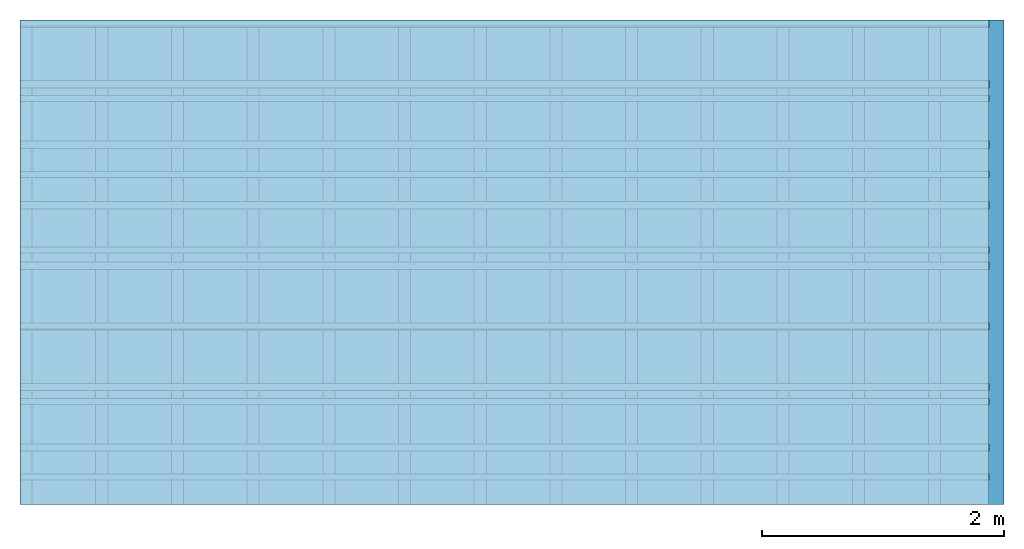
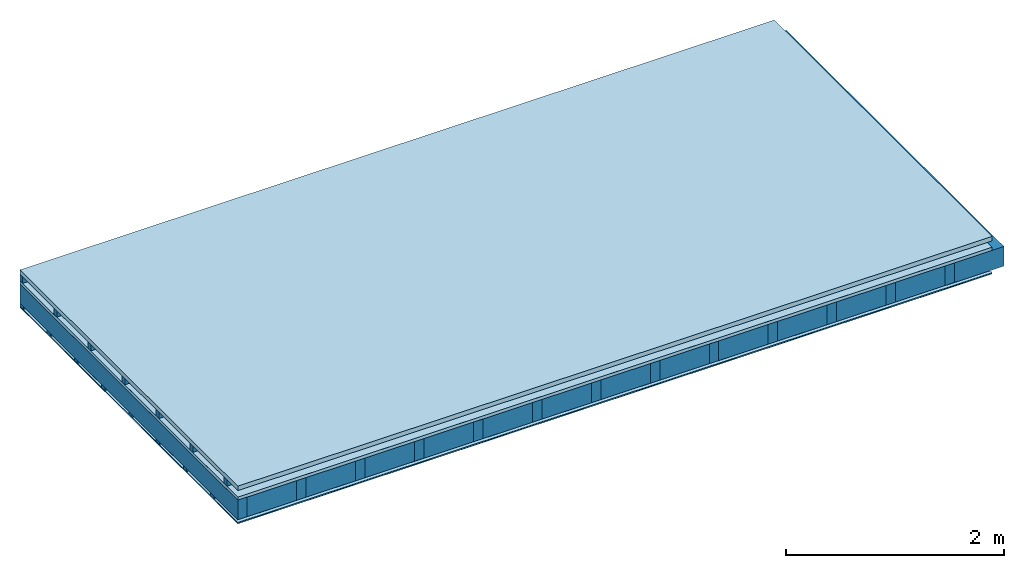
# One storey: 6 plates, 4 members, 1 element without a shape of its own.
"""IFC4 building model written with IfcOpenShell, lengths in metres."""

from ifc_helpers import new_model, si_unit, derived_unit, direction, frame, frame_2d, origin, origin_with_axes, place, context, project, spatial, rectangle, extrude, material, layer, layer_set, type_object, element, aggregate, save


model = new_model("IFC4")

# Units and contexts
plan_context = context("Plan", 3, precision=1e-05, world=origin(), true_north=direction((0.0, 1.0)))
model_context = context("Model", 3, precision=1e-05, world=origin(), true_north=direction((0.0, 1.0)))
ifc_project = project(units=[si_unit("LENGTHUNIT", "METRE"), derived_unit("SOUNDPRESSUREUNIT", [(si_unit("PRESSUREUNIT", "PASCAL", prefix="MICRO"), 0)]), si_unit("ENERGYUNIT", "JOULE", prefix="MEGA"), si_unit("MASSUNIT", "GRAM", prefix="KILO"), derived_unit("THERMALTRANSMITTANCEUNIT", [(si_unit("POWERUNIT", "WATT"), 1), (si_unit("AREAUNIT", "SQUARE_METRE"), -1), (si_unit("THERMODYNAMICTEMPERATUREUNIT", "KELVIN"), -1)]), derived_unit("AREADENSITYUNIT", [(si_unit("MASSUNIT", "GRAM", prefix="KILO"), 1), (si_unit("AREAUNIT", "SQUARE_METRE"), -1)]), derived_unit("USERDEFINED", [(si_unit("ENERGYUNIT", "JOULE", prefix="MEGA"), 1), (si_unit("AREAUNIT", "SQUARE_METRE"), -1)])], contexts=[plan_context, model_context])

# Site, building, storey
site = spatial("IfcSite", under=ifc_project)
building_placement = place(None, origin())
building = spatial("IfcBuilding", under=site, at=building_placement)
storey_placement = place(building_placement, origin())
storey = spatial("IfcBuildingStorey", under=building, at=storey_placement)

# Slab, members, plates
ifc_material_1 = material(Name="Roof tiles", Category="03.015")
ifc_layer_1 = layer(ifc_material_1, 0.05, Name="Roofing")
ifc_layer_2 = layer(None, 0.072, Name="Battens / profiles")
ifc_material_2 = material(Name="Roofing underlay", Category="09.008")
ifc_layer_3 = layer(ifc_material_2, 0.00018, Name="Under the roof")
ifc_material_3 = material(Category="10.009")
ifc_layer_4 = layer(ifc_material_3, 0.035, Name="Sub-floor")
ifc_material_4 = material(Name="of the art")
ifc_layer_5 = layer(ifc_material_4, 0.0, Name="Bond")
ifc_layer_6 = layer(None, 0.22, Name="Supporting structure")
ifc_material_5 = material(Name="Vapor barrier polyethylene (PE)", Category="09.002")
ifc_layer_7 = layer(ifc_material_5, 0.00025, Name="Vapor barrier")
ifc_layer_8 = layer(None, 0.03, Name="Battens / profiles")
ifc_material_6 = material(Name="Plasterboard type A", Category="03.008")
ifc_layer_9 = layer(ifc_material_6, 0.0125, Name="Covering below 1st layer")
ifc_material_7 = material(Category="04.001")
ifc_layer_10 = layer(ifc_material_7, 0.003, Name="Surface below")
ifc_layer_set = layer_set([ifc_layer_1, ifc_layer_2, ifc_layer_3, ifc_layer_4, ifc_layer_5, ifc_layer_6, ifc_layer_7, ifc_layer_8, ifc_layer_9, ifc_layer_10])
slab_type = type_object("IfcSlabType", Name="E0188", PredefinedType="NOTDEFINED", material=ifc_layer_set)
slab_placement = place(None, frame((0.0, 0.0, 0.0), z_axis=(0.0, 0.0, -1.0), x_axis=(1.0, 0.0, 0.0)))
slab = element("IfcSlab", 1, at=slab_placement, inside=storey, type_object=slab_type, material=ifc_layer_set, Name="Slab #1")
ifc_material_8 = material()
member_1_placement = place(slab_placement, origin())
member_1 = element("IfcMember", 2, at=member_1_placement, material=ifc_material_8, Name="Battens / profiles", context=plan_context, shape_type="SweptSolid", body=[
    extrude(rectangle(XDim=0.05, YDim=0.072, at=frame_2d((0.025, 0.036), x_axis=(1.0, 0.0))), frame((0.0, 0.0, 0.05), z_axis=(1.0, 0.0, 0.0), x_axis=(0.0, 1.0, 0.0)), (0.0, 0.0, 1.0), 8.0),
    extrude(rectangle(XDim=0.05, YDim=0.072, at=frame_2d((0.025, 0.036), x_axis=(1.0, 0.0))), frame((0.0, 0.625, 0.05), z_axis=(1.0, 0.0, 0.0), x_axis=(0.0, 1.0, 0.0)), (0.0, 0.0, 1.0), 8.0),
    extrude(rectangle(XDim=0.05, YDim=0.072, at=frame_2d((0.025, 0.036), x_axis=(1.0, 0.0))), frame((0.0, 1.25, 0.05), z_axis=(1.0, 0.0, 0.0), x_axis=(0.0, 1.0, 0.0)), (0.0, 0.0, 1.0), 8.0),
    extrude(rectangle(XDim=0.05, YDim=0.072, at=frame_2d((0.025, 0.036), x_axis=(1.0, 0.0))), frame((0.0, 1.875, 0.05), z_axis=(1.0, 0.0, 0.0), x_axis=(0.0, 1.0, 0.0)), (0.0, 0.0, 1.0), 8.0),
    extrude(rectangle(XDim=0.05, YDim=0.072, at=frame_2d((0.025, 0.036), x_axis=(1.0, 0.0))), frame((0.0, 2.5, 0.05), z_axis=(1.0, 0.0, 0.0), x_axis=(0.0, 1.0, 0.0)), (0.0, 0.0, 1.0), 8.0),
    extrude(rectangle(XDim=0.05, YDim=0.072, at=frame_2d((0.025, 0.036), x_axis=(1.0, 0.0))), frame((0.0, 3.125, 0.05), z_axis=(1.0, 0.0, 0.0), x_axis=(0.0, 1.0, 0.0)), (0.0, 0.0, 1.0), 8.0),
    extrude(rectangle(XDim=0.05, YDim=0.072, at=frame_2d((0.025, 0.036), x_axis=(1.0, 0.0))), frame((0.0, 3.75, 0.05), z_axis=(1.0, 0.0, 0.0), x_axis=(0.0, 1.0, 0.0)), (0.0, 0.0, 1.0), 8.0),
])
ifc_material_9 = material()
member_2_placement = place(slab_placement, origin())
member_2 = element("IfcMember", 3, at=member_2_placement, material=ifc_material_9, Name="Supporting structure", context=plan_context, shape_type="SweptSolid", body=[
    extrude(rectangle(XDim=0.1, YDim=0.22, at=frame_2d((0.05, 0.11), x_axis=(1.0, 0.0))), frame((0.0, 4.0, 0.15718), z_axis=(0.0, -1.0, 0.0), x_axis=(1.0, 0.0, 0.0)), (0.0, 0.0, 1.0), 4.0),
    extrude(rectangle(XDim=0.1, YDim=0.22, at=frame_2d((0.05, 0.11), x_axis=(1.0, 0.0))), frame((0.625, 4.0, 0.15718), z_axis=(0.0, -1.0, 0.0), x_axis=(1.0, 0.0, 0.0)), (0.0, 0.0, 1.0), 4.0),
    extrude(rectangle(XDim=0.1, YDim=0.22, at=frame_2d((0.05, 0.11), x_axis=(1.0, 0.0))), frame((1.25, 4.0, 0.15718), z_axis=(0.0, -1.0, 0.0), x_axis=(1.0, 0.0, 0.0)), (0.0, 0.0, 1.0), 4.0),
    extrude(rectangle(XDim=0.1, YDim=0.22, at=frame_2d((0.05, 0.11), x_axis=(1.0, 0.0))), frame((1.875, 4.0, 0.15718), z_axis=(0.0, -1.0, 0.0), x_axis=(1.0, 0.0, 0.0)), (0.0, 0.0, 1.0), 4.0),
    extrude(rectangle(XDim=0.1, YDim=0.22, at=frame_2d((0.05, 0.11), x_axis=(1.0, 0.0))), frame((2.5, 4.0, 0.15718), z_axis=(0.0, -1.0, 0.0), x_axis=(1.0, 0.0, 0.0)), (0.0, 0.0, 1.0), 4.0),
    extrude(rectangle(XDim=0.1, YDim=0.22, at=frame_2d((0.05, 0.11), x_axis=(1.0, 0.0))), frame((3.125, 4.0, 0.15718), z_axis=(0.0, -1.0, 0.0), x_axis=(1.0, 0.0, 0.0)), (0.0, 0.0, 1.0), 4.0),
    extrude(rectangle(XDim=0.1, YDim=0.22, at=frame_2d((0.05, 0.11), x_axis=(1.0, 0.0))), frame((3.75, 4.0, 0.15718), z_axis=(0.0, -1.0, 0.0), x_axis=(1.0, 0.0, 0.0)), (0.0, 0.0, 1.0), 4.0),
    extrude(rectangle(XDim=0.1, YDim=0.22, at=frame_2d((0.05, 0.11), x_axis=(1.0, 0.0))), frame((4.375, 4.0, 0.15718), z_axis=(0.0, -1.0, 0.0), x_axis=(1.0, 0.0, 0.0)), (0.0, 0.0, 1.0), 4.0),
    extrude(rectangle(XDim=0.1, YDim=0.22, at=frame_2d((0.05, 0.11), x_axis=(1.0, 0.0))), frame((5.0, 4.0, 0.15718), z_axis=(0.0, -1.0, 0.0), x_axis=(1.0, 0.0, 0.0)), (0.0, 0.0, 1.0), 4.0),
    extrude(rectangle(XDim=0.1, YDim=0.22, at=frame_2d((0.05, 0.11), x_axis=(1.0, 0.0))), frame((5.625, 4.0, 0.15718), z_axis=(0.0, -1.0, 0.0), x_axis=(1.0, 0.0, 0.0)), (0.0, 0.0, 1.0), 4.0),
    extrude(rectangle(XDim=0.1, YDim=0.22, at=frame_2d((0.05, 0.11), x_axis=(1.0, 0.0))), frame((6.25, 4.0, 0.15718), z_axis=(0.0, -1.0, 0.0), x_axis=(1.0, 0.0, 0.0)), (0.0, 0.0, 1.0), 4.0),
    extrude(rectangle(XDim=0.1, YDim=0.22, at=frame_2d((0.05, 0.11), x_axis=(1.0, 0.0))), frame((6.875, 4.0, 0.15718), z_axis=(0.0, -1.0, 0.0), x_axis=(1.0, 0.0, 0.0)), (0.0, 0.0, 1.0), 4.0),
    extrude(rectangle(XDim=0.1, YDim=0.22, at=frame_2d((0.05, 0.11), x_axis=(1.0, 0.0))), frame((7.5, 4.0, 0.15718), z_axis=(0.0, -1.0, 0.0), x_axis=(1.0, 0.0, 0.0)), (0.0, 0.0, 1.0), 4.0),
])
ifc_material_10 = material(Name="Mineral wool")
member_3_placement = place(slab_placement, origin())
member_3 = element("IfcMember", 4, at=member_3_placement, material=ifc_material_10, Name="Cavity", context=plan_context, shape_type="SweptSolid", body=[
    extrude(rectangle(XDim=0.525, YDim=0.22, at=frame_2d((0.2625, 0.11), x_axis=(1.0, 0.0))), frame((0.1, 4.0, 0.15718), z_axis=(0.0, -1.0, 0.0), x_axis=(1.0, 0.0, 0.0)), (0.0, 0.0, 1.0), 4.0),
    extrude(rectangle(XDim=0.525, YDim=0.22, at=frame_2d((0.2625, 0.11), x_axis=(1.0, 0.0))), frame((0.725, 4.0, 0.15718), z_axis=(0.0, -1.0, 0.0), x_axis=(1.0, 0.0, 0.0)), (0.0, 0.0, 1.0), 4.0),
    extrude(rectangle(XDim=0.525, YDim=0.22, at=frame_2d((0.2625, 0.11), x_axis=(1.0, 0.0))), frame((1.35, 4.0, 0.15718), z_axis=(0.0, -1.0, 0.0), x_axis=(1.0, 0.0, 0.0)), (0.0, 0.0, 1.0), 4.0),
    extrude(rectangle(XDim=0.525, YDim=0.22, at=frame_2d((0.2625, 0.11), x_axis=(1.0, 0.0))), frame((1.975, 4.0, 0.15718), z_axis=(0.0, -1.0, 0.0), x_axis=(1.0, 0.0, 0.0)), (0.0, 0.0, 1.0), 4.0),
    extrude(rectangle(XDim=0.525, YDim=0.22, at=frame_2d((0.2625, 0.11), x_axis=(1.0, 0.0))), frame((2.6, 4.0, 0.15718), z_axis=(0.0, -1.0, 0.0), x_axis=(1.0, 0.0, 0.0)), (0.0, 0.0, 1.0), 4.0),
    extrude(rectangle(XDim=0.525, YDim=0.22, at=frame_2d((0.2625, 0.11), x_axis=(1.0, 0.0))), frame((3.225, 4.0, 0.15718), z_axis=(0.0, -1.0, 0.0), x_axis=(1.0, 0.0, 0.0)), (0.0, 0.0, 1.0), 4.0),
    extrude(rectangle(XDim=0.525, YDim=0.22, at=frame_2d((0.2625, 0.11), x_axis=(1.0, 0.0))), frame((3.85, 4.0, 0.15718), z_axis=(0.0, -1.0, 0.0), x_axis=(1.0, 0.0, 0.0)), (0.0, 0.0, 1.0), 4.0),
    extrude(rectangle(XDim=0.525, YDim=0.22, at=frame_2d((0.2625, 0.11), x_axis=(1.0, 0.0))), frame((4.475, 4.0, 0.15718), z_axis=(0.0, -1.0, 0.0), x_axis=(1.0, 0.0, 0.0)), (0.0, 0.0, 1.0), 4.0),
    extrude(rectangle(XDim=0.525, YDim=0.22, at=frame_2d((0.2625, 0.11), x_axis=(1.0, 0.0))), frame((5.1, 4.0, 0.15718), z_axis=(0.0, -1.0, 0.0), x_axis=(1.0, 0.0, 0.0)), (0.0, 0.0, 1.0), 4.0),
    extrude(rectangle(XDim=0.525, YDim=0.22, at=frame_2d((0.2625, 0.11), x_axis=(1.0, 0.0))), frame((5.725, 4.0, 0.15718), z_axis=(0.0, -1.0, 0.0), x_axis=(1.0, 0.0, 0.0)), (0.0, 0.0, 1.0), 4.0),
    extrude(rectangle(XDim=0.525, YDim=0.22, at=frame_2d((0.2625, 0.11), x_axis=(1.0, 0.0))), frame((6.35, 4.0, 0.15718), z_axis=(0.0, -1.0, 0.0), x_axis=(1.0, 0.0, 0.0)), (0.0, 0.0, 1.0), 4.0),
    extrude(rectangle(XDim=0.525, YDim=0.22, at=frame_2d((0.2625, 0.11), x_axis=(1.0, 0.0))), frame((6.975, 4.0, 0.15718), z_axis=(0.0, -1.0, 0.0), x_axis=(1.0, 0.0, 0.0)), (0.0, 0.0, 1.0), 4.0),
    extrude(rectangle(XDim=0.525, YDim=0.22, at=frame_2d((0.2625, 0.11), x_axis=(1.0, 0.0))), frame((7.6, 4.0, 0.15718), z_axis=(0.0, -1.0, 0.0), x_axis=(1.0, 0.0, 0.0)), (0.0, 0.0, 1.0), 4.0),
])
ifc_material_11 = material()
member_4_placement = place(slab_placement, origin())
member_4 = element("IfcMember", 5, at=member_4_placement, material=ifc_material_11, Name="Battens / profiles", context=plan_context, shape_type="SweptSolid", body=[
    extrude(rectangle(XDim=0.06, YDim=0.03, at=frame_2d((0.03, 0.015), x_axis=(1.0, 0.0))), frame((0.0, 0.0, 0.37743), z_axis=(1.0, 0.0, 0.0), x_axis=(0.0, 1.0, 0.0)), (0.0, 0.0, 1.0), 8.0),
    extrude(rectangle(XDim=0.06, YDim=0.03, at=frame_2d((0.03, 0.015), x_axis=(1.0, 0.0))), frame((0.0, 0.5, 0.37743), z_axis=(1.0, 0.0, 0.0), x_axis=(0.0, 1.0, 0.0)), (0.0, 0.0, 1.0), 8.0),
    extrude(rectangle(XDim=0.06, YDim=0.03, at=frame_2d((0.03, 0.015), x_axis=(1.0, 0.0))), frame((0.0, 1.0, 0.37743), z_axis=(1.0, 0.0, 0.0), x_axis=(0.0, 1.0, 0.0)), (0.0, 0.0, 1.0), 8.0),
    extrude(rectangle(XDim=0.06, YDim=0.03, at=frame_2d((0.03, 0.015), x_axis=(1.0, 0.0))), frame((0.0, 1.5, 0.37743), z_axis=(1.0, 0.0, 0.0), x_axis=(0.0, 1.0, 0.0)), (0.0, 0.0, 1.0), 8.0),
    extrude(rectangle(XDim=0.06, YDim=0.03, at=frame_2d((0.03, 0.015), x_axis=(1.0, 0.0))), frame((0.0, 2.0, 0.37743), z_axis=(1.0, 0.0, 0.0), x_axis=(0.0, 1.0, 0.0)), (0.0, 0.0, 1.0), 8.0),
    extrude(rectangle(XDim=0.06, YDim=0.03, at=frame_2d((0.03, 0.015), x_axis=(1.0, 0.0))), frame((0.0, 2.5, 0.37743), z_axis=(1.0, 0.0, 0.0), x_axis=(0.0, 1.0, 0.0)), (0.0, 0.0, 1.0), 8.0),
    extrude(rectangle(XDim=0.06, YDim=0.03, at=frame_2d((0.03, 0.015), x_axis=(1.0, 0.0))), frame((0.0, 3.0, 0.37743), z_axis=(1.0, 0.0, 0.0), x_axis=(0.0, 1.0, 0.0)), (0.0, 0.0, 1.0), 8.0),
    extrude(rectangle(XDim=0.06, YDim=0.03, at=frame_2d((0.03, 0.015), x_axis=(1.0, 0.0))), frame((0.0, 3.5, 0.37743), z_axis=(1.0, 0.0, 0.0), x_axis=(0.0, 1.0, 0.0)), (0.0, 0.0, 1.0), 8.0),
])
plate_1_placement = place(slab_placement, origin())
plate_1 = element("IfcPlate", 6, at=plate_1_placement, material=ifc_material_1, Name="Roofing", context=plan_context, shape_type="SweptSolid", body=[
    extrude(rectangle(XDim=8.0, YDim=4.0, at=frame_2d((4.0, 2.0), x_axis=(1.0, 0.0))), origin_with_axes(), (0.0, 0.0, 1.0), 0.05),
])
plate_2_placement = place(slab_placement, origin())
plate_2 = element("IfcPlate", 7, at=plate_2_placement, material=ifc_material_2, Name="Under the roof", context=plan_context, shape_type="SweptSolid", body=[
    extrude(rectangle(XDim=8.0, YDim=4.0, at=frame_2d((4.0, 2.0), x_axis=(1.0, 0.0))), frame((0.0, 0.0, 0.122), z_axis=(0.0, 0.0, 1.0), x_axis=(1.0, 0.0, 0.0)), (0.0, 0.0, 1.0), 0.00018),
])
plate_3_placement = place(slab_placement, origin())
plate_3 = element("IfcPlate", 8, at=plate_3_placement, material=ifc_material_3, Name="Sub-floor", context=plan_context, shape_type="SweptSolid", body=[
    extrude(rectangle(XDim=8.0, YDim=4.0, at=frame_2d((4.0, 2.0), x_axis=(1.0, 0.0))), frame((0.0, 0.0, 0.12218), z_axis=(0.0, 0.0, 1.0), x_axis=(1.0, 0.0, 0.0)), (0.0, 0.0, 1.0), 0.035),
])
plate_4_placement = place(slab_placement, origin())
plate_4 = element("IfcPlate", 9, at=plate_4_placement, material=ifc_material_5, Name="Vapor barrier", context=plan_context, shape_type="SweptSolid", body=[
    extrude(rectangle(XDim=8.0, YDim=4.0, at=frame_2d((4.0, 2.0), x_axis=(1.0, 0.0))), frame((0.0, 0.0, 0.37718), z_axis=(0.0, 0.0, 1.0), x_axis=(1.0, 0.0, 0.0)), (0.0, 0.0, 1.0), 0.00025),
])
plate_5_placement = place(slab_placement, origin())
plate_5 = element("IfcPlate", 10, at=plate_5_placement, material=ifc_material_6, Name="Covering below 1st layer", context=plan_context, shape_type="SweptSolid", body=[
    extrude(rectangle(XDim=8.0, YDim=4.0, at=frame_2d((4.0, 2.0), x_axis=(1.0, 0.0))), frame((0.0, 0.0, 0.40743), z_axis=(0.0, 0.0, 1.0), x_axis=(1.0, 0.0, 0.0)), (0.0, 0.0, 1.0), 0.0125),
])
plate_6_placement = place(slab_placement, origin())
plate_6 = element("IfcPlate", 11, at=plate_6_placement, material=ifc_material_7, Name="Surface below", context=plan_context, shape_type="SweptSolid", body=[
    extrude(rectangle(XDim=8.0, YDim=4.0, at=frame_2d((4.0, 2.0), x_axis=(1.0, 0.0))), frame((0.0, 0.0, 0.41993), z_axis=(0.0, 0.0, 1.0), x_axis=(1.0, 0.0, 0.0)), (0.0, 0.0, 1.0), 0.003),
])
aggregate(slab, [plate_1, member_1, plate_2, plate_3, member_2, member_3, plate_4, member_4, plate_5, plate_6])

save(model, "model.ifc")
